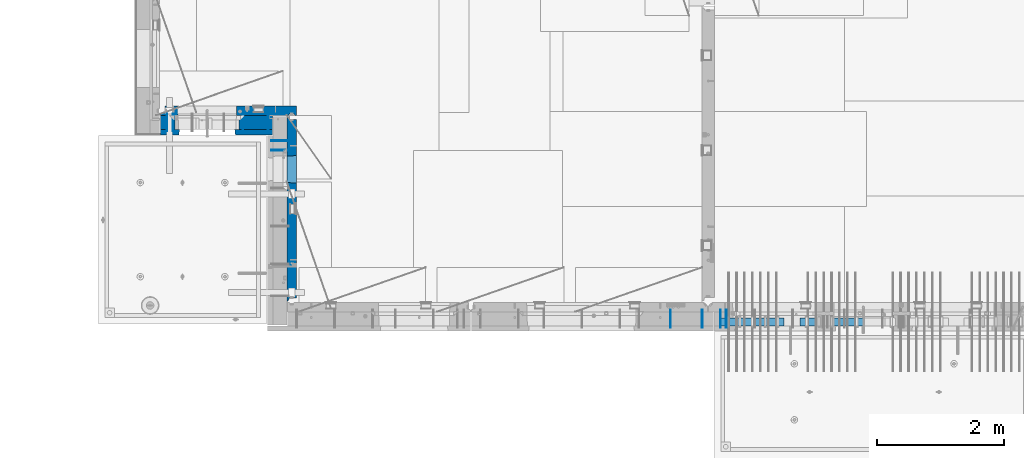
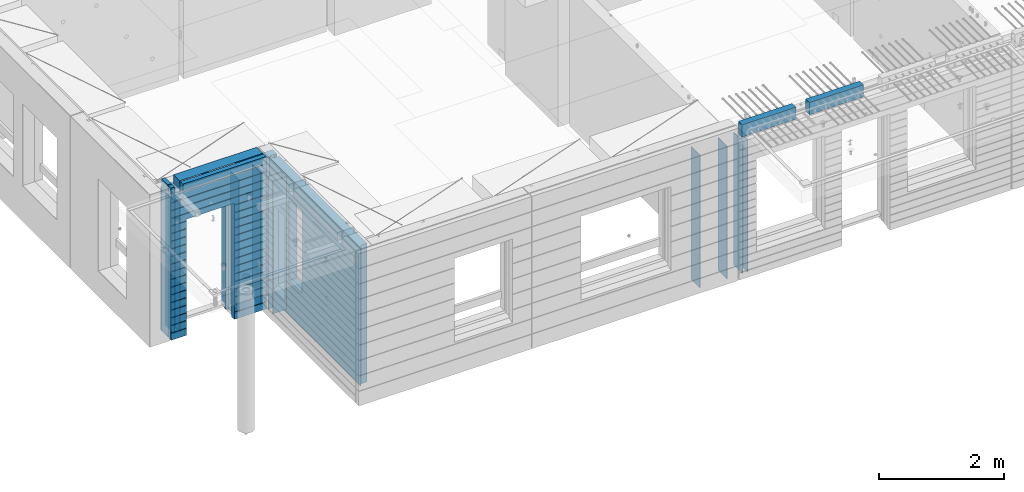
# One storey, part 218 of 334: 16 walls, 7 elements without a shape of their own.
"""IFC2X3 building model written with IfcOpenShell, lengths in millimetres."""

from ifc_helpers import new_model, si_unit, frame, origin_with_axes, place, context, subcontext, project, spatial, faceted_brep, material, type_object, element, aggregate, save


model = new_model("IFC2X3")

# Units and contexts
model_context = context("Model", 3, precision=1e-05, world=origin_with_axes())
body_context = subcontext(model_context, "Body", "Model", "MODEL_VIEW")
ifc_project = project(units=[si_unit("LENGTHUNIT", "METRE", prefix="MILLI"), si_unit("AREAUNIT", "SQUARE_METRE"), si_unit("VOLUMEUNIT", "CUBIC_METRE"), si_unit("MASSUNIT", "GRAM", prefix="KILO"), si_unit("TIMEUNIT", "SECOND"), si_unit("PLANEANGLEUNIT", "RADIAN"), si_unit("SOLIDANGLEUNIT", "STERADIAN"), si_unit("THERMODYNAMICTEMPERATUREUNIT", "DEGREE_CELSIUS"), si_unit("LUMINOUSINTENSITYUNIT", "LUMEN")], contexts=[model_context])

# Site, building, storey
site_placement = place(None, origin_with_axes())
site = spatial("IfcSite", under=ifc_project, at=site_placement, CompositionType="ELEMENT")
building_placement = place(site_placement, origin_with_axes())
building = spatial("IfcBuilding", under=site, at=building_placement, CompositionType="ELEMENT")
storey_placement = place(building_placement, origin_with_axes())
storey = spatial("IfcBuildingStorey", under=building, at=storey_placement, Name="3", CompositionType="ELEMENT", Elevation=0.0)

# Assembly, wall
assembly_1_placement = place(storey_placement, origin_with_axes())
assembly_1 = element("IfcElementAssembly", 1, at=assembly_1_placement, inside=storey, AssemblyPlace="NOTDEFINED", PredefinedType="REINFORCEMENT_UNIT")
ifc_material_1 = material(Name="Undefined")
wall_type_1 = type_object("IfcWallType", PredefinedType="NOTDEFINED")
wall_1_placement = place(assembly_1_placement, frame((16855.0, 7880.0, 89115.0), z_axis=(0.0, 0.0, 1.0), x_axis=(0.0, -1.0, 0.0)))
wall_1 = element("IfcWall", 2, at=wall_1_placement, type_object=wall_type_1, material=ifc_material_1, Name="(PD)", context=body_context, shape_type="Brep", body=[
    faceted_brep([(0.0, 5.0, -1300.0), (0.0, 5.0, 1300.0), (280.0, 5.0, 1300.0), (280.0, 5.0, -1300.0), (0.0, -5.0, 1300.0), (280.0, -5.0, 1300.0), (0.0, -5.0, -1300.0), (280.0, -5.0, -1300.0)], [[[0, 1, 2, 3]], [[1, 4, 5, 2]], [[4, 6, 7, 5]], [[6, 0, 3, 7]], [[5, 7, 3, 2]], [[6, 4, 1, 0]]]),
])

# Assembly, walls
assembly_2_placement = place(storey_placement, origin_with_axes())
assembly_2 = element("IfcElementAssembly", 3, at=assembly_2_placement, inside=storey, AssemblyPlace="NOTDEFINED", PredefinedType="REINFORCEMENT_UNIT")
wall_2_placement = place(assembly_2_placement, frame((16565.0, 7880.0, 89115.0), z_axis=(0.0, 0.0, 1.0), x_axis=(0.0, -1.0, 0.0)))
wall_2 = element("IfcWall", 4, at=wall_2_placement, type_object=wall_type_1, material=ifc_material_1, Name="(PD)", context=body_context, shape_type="Brep", body=[
    faceted_brep([(0.0, 5.0, -1300.0), (0.0, 5.0, 1300.0), (280.0, 5.0, 1300.0), (280.0, 5.0, -1300.0), (0.0, -5.0, 1300.0), (280.0, -5.0, 1300.0), (0.0, -5.0, -1300.0), (280.0, -5.0, -1300.0)], [[[0, 1, 2, 3]], [[1, 4, 5, 2]], [[4, 6, 7, 5]], [[6, 0, 3, 7]], [[5, 7, 3, 2]], [[6, 4, 1, 0]]]),
])
wall_3_placement = place(assembly_2_placement, frame((16065.0, 7880.0, 89115.0), z_axis=(0.0, 0.0, 1.0), x_axis=(0.0, -1.0, 0.0)))
wall_3 = element("IfcWall", 5, at=wall_3_placement, type_object=wall_type_1, material=ifc_material_1, Name="(PD)", context=body_context, shape_type="Brep", body=[
    faceted_brep([(0.0, 5.0, -1300.0), (0.0, 5.0, 1300.0), (280.0, 5.0, 1300.0), (280.0, 5.0, -1300.0), (0.0, -5.0, 1300.0), (280.0, -5.0, 1300.0), (0.0, -5.0, -1300.0), (280.0, -5.0, -1300.0)], [[[0, 1, 2, 3]], [[1, 4, 5, 2]], [[4, 6, 7, 5]], [[6, 0, 3, 7]], [[5, 7, 3, 2]], [[6, 4, 1, 0]]]),
])
aggregate(assembly_2, [wall_2, wall_3])

# Assembly, wall
assembly_3_placement = place(storey_placement, origin_with_axes())
assembly_3 = element("IfcElementAssembly", 6, at=assembly_3_placement, inside=storey, AssemblyPlace="NOTDEFINED", PredefinedType="REINFORCEMENT_UNIT")
wall_4_placement = place(assembly_3_placement, frame((8215.0, 10980.0, 89115.0), z_axis=(0.0, 0.0, 1.0), x_axis=(0.0, -1.0, 0.0)))
wall_4 = element("IfcWall", 7, at=wall_4_placement, type_object=wall_type_1, material=ifc_material_1, Name="(PD)", context=body_context, shape_type="Brep", body=[
    faceted_brep([(0.0, 5.0, -1300.0), (0.0, 5.0, 1300.0), (280.0, 5.0, 1300.0), (280.0, 5.0, -1300.0), (0.0, -5.0, 1300.0), (280.0, -5.0, 1300.0), (0.0, -5.0, -1300.0), (280.0, -5.0, -1300.0)], [[[0, 1, 2, 3]], [[1, 4, 5, 2]], [[4, 6, 7, 5]], [[6, 0, 3, 7]], [[5, 7, 3, 2]], [[6, 4, 1, 0]]]),
])

# Wall
wall_5_placement = place(assembly_1_placement, frame((16945.0, 7880.0, 89115.0), z_axis=(0.0, 0.0, 1.0), x_axis=(0.0, -1.0, 0.0)))
wall_5 = element("IfcWall", 8, at=wall_5_placement, type_object=wall_type_1, material=ifc_material_1, Name="(PD)", context=body_context, shape_type="Brep", body=[
    faceted_brep([(0.0, 5.0, -1300.0), (0.0, 5.0, 1300.0), (280.0, 5.0, 1300.0), (280.0, 5.0, -1300.0), (0.0, -5.0, 1300.0), (280.0, -5.0, 1300.0), (0.0, -5.0, -1300.0), (280.0, -5.0, -1300.0)], [[[0, 1, 2, 3]], [[1, 4, 5, 2]], [[4, 6, 7, 5]], [[6, 0, 3, 7]], [[5, 7, 3, 2]], [[6, 4, 1, 0]]]),
])

aggregate(assembly_1, [wall_1, wall_5])

wall_6_placement = place(assembly_3_placement, frame((8115.0, 10980.0, 89115.0), z_axis=(0.0, 0.0, 1.0), x_axis=(0.0, -1.0, 0.0)))
wall_6 = element("IfcWall", 9, at=wall_6_placement, type_object=wall_type_1, material=ifc_material_1, Name="(PD)", context=body_context, shape_type="Brep", body=[
    faceted_brep([(0.0, 5.0, -1300.0), (0.0, 5.0, 1300.0), (280.0, 5.0, 1300.0), (280.0, 5.0, -1300.0), (0.0, -5.0, 1300.0), (280.0, -5.0, 1300.0), (0.0, -5.0, -1300.0), (280.0, -5.0, -1300.0)], [[[0, 1, 2, 3]], [[1, 4, 5, 2]], [[4, 6, 7, 5]], [[6, 0, 3, 7]], [[5, 7, 3, 2]], [[6, 4, 1, 0]]]),
])

wall_7_placement = place(assembly_3_placement, frame((9315.0, 10980.0, 89115.0), z_axis=(0.0, 0.0, 1.0), x_axis=(0.0, -1.0, 0.0)))
wall_7 = element("IfcWall", 10, at=wall_7_placement, type_object=wall_type_1, material=ifc_material_1, Name="(PD)", context=body_context, shape_type="Brep", body=[
    faceted_brep([(0.0, 5.0, -1300.0), (0.0, 5.0, 1300.0), (280.0, 5.0, 1300.0), (280.0, 5.0, -1300.0), (0.0, -5.0, 1300.0), (280.0, -5.0, 1300.0), (0.0, -5.0, -1300.0), (280.0, -5.0, -1300.0)], [[[0, 1, 2, 3]], [[1, 4, 5, 2]], [[4, 6, 7, 5]], [[6, 0, 3, 7]], [[5, 7, 3, 2]], [[6, 4, 1, 0]]]),
])

wall_8_placement = place(assembly_3_placement, frame((9715.0, 10980.0, 89115.0), z_axis=(0.0, 0.0, 1.0), x_axis=(0.0, -1.0, 0.0)))
wall_8 = element("IfcWall", 11, at=wall_8_placement, type_object=wall_type_1, material=ifc_material_1, Name="(PD)", context=body_context, shape_type="Brep", body=[
    faceted_brep([(0.0, 5.0, -1300.0), (0.0, 5.0, 1300.0), (280.0, 5.0, 1300.0), (280.0, 5.0, -1300.0), (0.0, -5.0, 1300.0), (280.0, -5.0, 1300.0), (0.0, -5.0, -1300.0), (280.0, -5.0, -1300.0)], [[[0, 1, 2, 3]], [[1, 4, 5, 2]], [[4, 6, 7, 5]], [[6, 0, 3, 7]], [[5, 7, 3, 2]], [[6, 4, 1, 0]]]),
])

# Assembly, walls
assembly_4_placement = place(storey_placement, origin_with_axes())
assembly_4 = element("IfcElementAssembly", 12, at=assembly_4_placement, inside=storey, AssemblyPlace="NOTDEFINED", PredefinedType="REINFORCEMENT_UNIT")
wall_9_placement = place(assembly_4_placement, frame((10040.0, 10400.0, 89115.0), z_axis=(0.0, 0.0, 1.0), x_axis=(-1.0, 3.00000001838171e-08, 0.0)))
wall_9 = element("IfcWall", 13, at=wall_9_placement, type_object=wall_type_1, material=ifc_material_1, Name="(PD)", context=body_context, shape_type="Brep", body=[
    faceted_brep([(0.0, 5.0, -1300.0), (0.0, 5.0, 1300.0), (280.0, 5.0, 1300.0), (280.0, 5.0, -1300.0), (0.0, -5.0, 1300.0), (280.0, -5.0, 1300.0), (0.0, -5.0, -1300.0), (280.0, -5.0, -1300.0)], [[[0, 1, 2, 3]], [[1, 4, 5, 2]], [[4, 6, 7, 5]], [[6, 0, 3, 7]], [[5, 7, 3, 2]], [[6, 4, 1, 0]]]),
])
wall_10_placement = place(assembly_4_placement, frame((10040.0, 10550.0, 89115.0), z_axis=(0.0, 0.0, 1.0), x_axis=(-1.0, 3.00000001838171e-08, 0.0)))
wall_10 = element("IfcWall", 14, at=wall_10_placement, type_object=wall_type_1, material=ifc_material_1, Name="(PD)", context=body_context, shape_type="Brep", body=[
    faceted_brep([(0.0, 5.0, -1300.0), (0.0, 5.0, 1300.0), (280.0, 5.0, 1300.0), (280.0, 5.0, -1300.0), (0.0, -5.0, 1300.0), (280.0, -5.0, 1300.0), (0.0, -5.0, -1300.0), (280.0, -5.0, -1300.0)], [[[0, 1, 2, 3]], [[1, 4, 5, 2]], [[4, 6, 7, 5]], [[6, 0, 3, 7]], [[5, 7, 3, 2]], [[6, 4, 1, 0]]]),
])

# Assemblies, walls
assembly_5_placement = place(storey_placement, origin_with_axes())
assembly_5 = element("IfcElementAssembly", 15, at=assembly_5_placement, inside=storey, AssemblyPlace="NOTDEFINED", PredefinedType="REINFORCEMENT_UNIT")
assembly_6_placement = place(assembly_5_placement, origin_with_axes())
assembly_6 = element("IfcElementAssembly", 16, at=assembly_6_placement, Name="Steel Assembly", AssemblyPlace="NOTDEFINED", PredefinedType="NOTDEFINED")
ifc_material_2 = material()
wall_type_2 = type_object("IfcWallType", PredefinedType="NOTDEFINED")
wall_11_placement = place(assembly_6_placement, frame((16859.9998568133, 7690.00021946163, 90590.0), z_axis=(0.0, 0.0, 1.0), x_axis=(1.0, 0.0, 0.0)))
wall_11 = element("IfcWall", 17, at=wall_11_placement, type_object=wall_type_2, material=ifc_material_2, context=body_context, shape_type="Brep", body=[
    faceted_brep([(0.0, 60.0, -120.0), (0.0, 60.0, 120.0), (1000.0, 60.0, 120.0), (1000.0, 60.0, -120.0), (0.0, -60.0, 120.0), (1000.0, -60.0, 120.0), (0.0, -60.0, -120.0), (1000.0, -60.0, -120.0)], [[[0, 1, 2, 3]], [[1, 4, 5, 2]], [[4, 6, 7, 5]], [[6, 0, 3, 7]], [[5, 7, 3, 2]], [[6, 4, 1, 0]]]),
])
aggregate(assembly_6, [wall_11])
assembly_7_placement = place(assembly_5_placement, origin_with_axes())
assembly_7 = element("IfcElementAssembly", 18, at=assembly_7_placement, Name="Steel Assembly", AssemblyPlace="NOTDEFINED", PredefinedType="NOTDEFINED")
aggregate(assembly_5, [assembly_7, assembly_6])
wall_12_placement = place(assembly_7_placement, frame((18109.9998568133, 7690.00021946163, 90590.0), z_axis=(0.0, 0.0, 1.0), x_axis=(1.0, 0.0, 0.0)))
wall_12 = element("IfcWall", 19, at=wall_12_placement, type_object=wall_type_2, material=ifc_material_2, context=body_context, shape_type="Brep", body=[
    faceted_brep([(0.0, 60.0, -120.0), (0.0, 60.0, 120.0), (1000.0, 60.0, 120.0), (1000.0, 60.0, -120.0), (0.0, -60.0, 120.0), (1000.0, -60.0, 120.0), (0.0, -60.0, -120.0), (1000.0, -60.0, -120.0)], [[[0, 1, 2, 3]], [[1, 4, 5, 2]], [[4, 6, 7, 5]], [[6, 0, 3, 7]], [[5, 7, 3, 2]], [[6, 4, 1, 0]]]),
])
aggregate(assembly_7, [wall_12])

# Wall
ifc_material_3 = material(Name="COS5gt")
wall_type_3 = type_object("IfcWallType", PredefinedType="NOTDEFINED")
wall_13_placement = place(assembly_3_placement, frame((9784.0, 10840.0, 89247.5), z_axis=(0.0, 0.0, 1.0), x_axis=(-1.0, 3.00000001838171e-08, 0.0)))
wall_13 = element("IfcWall", 20, at=wall_13_placement, type_object=wall_type_3, material=ifc_material_3, context=body_context, shape_type="Brep", body=[
    faceted_brep([(1699.0, -110.0, 1492.5), (1699.0, 90.0, 1492.5), (1699.0, 90.0, 1442.5), (1699.0, 110.0, 1442.5), (1699.0, 110.0, 1222.5), (1699.0, -110.0, 1222.5), (1549.0, 110.0, 1222.5), (1549.0, -110.0, 1222.5), (1549.0, -110.0, 1492.5), (1549.0, 110.0, 1442.5), (1549.0, 90.0, 1442.5), (1549.0, 90.0, 1492.5), (0.0, -110.0, -1492.5), (0.0, 90.0, -1492.5), (529.001442432404, 90.0, -1492.5), (529.001442432404, -110.0, -1492.5), (0.0, 90.0, -1442.5), (0.0, 110.0, -1442.5), (529.001442432404, 110.0, -1442.5), (529.001442432404, 90.0, -1442.5), (1769.0, 90.0, -1442.5), (1769.0, 90.0, -1492.5), (1539.0014424324, 90.0, -1492.5), (1539.0014424324, 90.0, -1442.5), (1769.0, 110.0, -1442.5), (1539.0014424324, 110.0, -1442.5), (1769.0, 110.0, 1442.5), (1769.0, 90.0, 1442.5), (1769.0, 90.0, 1492.5), (1769.0, -110.0, 1492.5), (1769.0, -110.0, -1492.5), (1539.0014424324, -110.0, -1492.5), (1539.0014424324, -110.0, 847.5), (1539.0014424324, 110.0, 847.5), (529.001442432404, -110.0, 847.5), (529.001442432404, 110.0, 847.5), (0.0, -110.0, 1492.5), (0.0, 90.0, 1492.5), (0.0, 90.0, 1442.5), (0.0, 110.0, 1442.5)], [[[0, 1, 2, 3, 4, 5]], [[5, 4, 6, 7]], [[8, 7, 6, 9, 10, 11]], [[12, 13, 14, 15]], [[16, 17, 18, 19]], [[20, 21, 22, 23]], [[24, 20, 23, 25]], [[26, 27, 28, 29, 30, 21, 20, 24]], [[21, 30, 31, 22]], [[32, 33, 25, 23, 22, 31]], [[34, 35, 33, 32]], [[15, 14, 19, 18, 35, 34]], [[13, 16, 19, 14]], [[13, 12, 36, 37, 38, 39, 17, 16]], [[37, 36, 8, 11]], [[38, 37, 11, 10]], [[39, 38, 10, 9]], [[4, 3, 26, 24, 25, 33, 35, 18, 17, 39, 9, 6]], [[27, 26, 3, 2]], [[28, 27, 2, 1]], [[29, 28, 1, 0]], [[36, 12, 15, 34, 32, 31, 30, 29, 0, 5, 7, 8]]]),
])

ifc_material_4 = material(Name="CONCRETE/C30/37")
wall_type_4 = type_object("IfcWallType", PredefinedType="NOTDEFINED")
wall_14_placement = place(assembly_3_placement, frame((9784.0, 10687.5, 89247.5), z_axis=(0.0, 0.0, 1.0), x_axis=(-1.0, 3.00000001838171e-08, 0.0)))
wall_14 = element("IfcWall", 21, at=wall_14_placement, type_object=wall_type_4, material=ifc_material_4, context=body_context, shape_type="Brep", body=[
    faceted_brep([(1699.0, -42.5, 1492.5), (1699.0, 42.5, 1492.5), (1699.0, 42.5, 1356.99999988925), (1699.0, 32.4999991126988, 1355.00000040044), (1699.0, 32.4999992506928, 1344.99999999921), (1699.0, 42.5, 1342.99999994476), (1699.0, 42.5, 1222.5), (1699.0, -42.5, 1222.5), (1549.0, 42.5, 1222.5), (1549.0, -42.5, 1222.5), (1549.0, -42.5, 1492.5), (1549.0, 42.5, 1342.99999994476), (1549.0, 32.4999992506928, 1344.99999999921), (1549.0, 32.4999991126988, 1355.00000040044), (1549.0, 42.5, 1356.99999988925), (1549.0, 42.5, 1492.5), (1478.99938360887, 42.5, 606.999999889245), (1769.0, 42.5, 606.999999889245), (1769.0, 32.4999991126988, 605.00000040044), (1477.8227168378, 32.4999991126988, 605.00000040044), (1769.0, 32.4999992506928, 594.999999999214), (1477.82271685404, 32.4999992506928, 594.999999999214), (1769.0, 42.5, 592.999999944761), (1478.99938360887, 42.5, 592.999999944761), (1769.0, 42.5, 456.999999889245), (1478.99938360887, 42.5, 456.999999889245), (1769.0, 32.4999991126988, 455.00000040044), (1477.8227168378, 32.4999991126988, 455.00000040044), (1769.0, 32.4999992506928, 444.999999999214), (1477.82271685404, 32.4999992506928, 444.999999999214), (1769.0, 42.5, 442.999999944761), (1478.99938360887, 42.5, 442.999999944761), (1769.0, 42.5, 306.999999889245), (1478.99938360887, 42.5, 306.999999889245), (1769.0, 32.4999991126988, 305.00000040044), (1477.8227168378, 32.4999991126988, 305.00000040044), (1769.0, 32.4999992506928, 294.999999999214), (1477.82271685404, 32.4999992506928, 294.999999999214), (1769.0, 42.5, 292.999999944761), (1478.99938360887, 42.5, 292.999999944761), (1769.0, 42.5, 156.999999889245), (1478.99938360887, 42.5, 156.999999889245), (1769.0, 32.4999991126988, 155.00000040044), (1477.8227168378, 32.4999991126988, 155.00000040044), (1769.0, 32.4999992506928, 144.999999999214), (1477.82271685404, 32.4999992506928, 144.999999999214), (1769.0, 42.5, 142.999999944761), (1478.99938360887, 42.5, 142.999999944761), (1769.0, 42.5, 6.99999988924537), (1478.99938360887, 42.5, 6.99999988924537), (1769.0, 32.4999991126988, 5.0000004004396), (1477.8227168378, 32.4999991126988, 5.0000004004396), (1769.0, 32.4999992506928, -5.0000000007858), (1477.82271685404, 32.4999992506928, -5.0000000007858), (1769.0, 42.5, -7.00000005523907), (1478.99938360887, 42.5, -7.00000005523907), (1769.0, 42.5, -143.000000110755), (1478.99938360887, 42.5, -143.000000110755), (1769.0, 32.4999991126988, -144.99999959956), (1477.8227168378, 32.4999991126988, -144.99999959956), (1769.0, 32.4999992506928, -155.000000000786), (1477.82271685404, 32.4999992506928, -155.000000000786), (1769.0, 42.5, -157.000000055239), (1478.99938360887, 42.5, -157.000000055239), (1769.0, 42.5, -293.000000110755), (1478.99938360887, 42.5, -293.000000110755), (1769.0, 32.4999991126988, -294.99999959956), (1477.8227168378, 32.4999991126988, -294.99999959956), (1769.0, 32.4999992506928, -305.000000000786), (1477.82271685404, 32.4999992506928, -305.000000000786), (1769.0, 42.5, -307.000000055239), (1478.99938360887, 42.5, -307.000000055239), (1769.0, 42.5, -443.000000110755), (1478.99938360887, 42.5, -443.000000110755), (1769.0, 32.4999991126988, -444.99999959956), (1477.8227168378, 32.4999991126988, -444.99999959956), (1769.0, 32.4999992506928, -455.000000000786), (1477.82271685404, 32.4999992506928, -455.000000000786), (1769.0, 42.5, -457.000000055239), (1478.99938360887, 42.5, -457.000000055239), (1769.0, 42.5, -593.000000110755), (1478.99938360887, 42.5, -593.000000110755), (1769.0, 32.4999991126988, -594.99999959956), (1477.8227168378, 32.4999991126988, -594.99999959956), (1769.0, 32.4999992506928, -605.000000000786), (1477.82271685404, 32.4999992506928, -605.000000000786), (1769.0, 42.5, -607.000000055239), (1478.99938360887, 42.5, -607.000000055239), (1769.0, 42.5, -743.000000110755), (1478.99938360887, 42.5, -743.000000110755), (1769.0, 32.4999991126988, -744.99999959956), (1477.8227168378, 32.4999991126988, -744.99999959956), (1769.0, 32.4999992506928, -755.000000000786), (1477.82271685404, 32.4999992506928, -755.000000000786), (1769.0, 42.5, -757.000000055239), (1478.99938360887, 42.5, -757.000000055239), (1769.0, 42.5, -893.000000110755), (1478.99938360887, 42.5, -893.000000110755), (1769.0, 32.4999991126988, -894.99999959956), (1477.8227168378, 32.4999991126988, -894.99999959956), (1769.0, 32.4999992506928, -905.000000000786), (1477.82271685404, 32.4999992506928, -905.000000000786), (1769.0, 42.5, -907.000000055239), (1478.99938360887, 42.5, -907.000000055239), (1769.0, 42.5, -1043.00000011075), (1478.99938360887, 42.5, -1043.00000011075), (1769.0, 32.4999991126988, -1044.99999959956), (1477.8227168378, 32.4999991126988, -1044.99999959956), (1769.0, 32.4999992506928, -1055.00000000079), (1477.82271685404, 32.4999992506928, -1055.00000000079), (1769.0, 42.5, -1057.00000005524), (1478.99938360887, 42.5, -1057.00000005524), (1769.0, 42.5, -1193.00000011075), (1478.99938360887, 42.5, -1193.00000011075), (1769.0, 32.4999991126988, -1194.99999959956), (1477.8227168378, 32.4999991126988, -1194.99999959956), (1769.0, 32.4999992506928, -1205.00000000079), (1477.82271685404, 32.4999992506928, -1205.00000000079), (1769.0, 42.5, -1207.00000005524), (1478.99938360887, 42.5, -1207.00000005524), (1769.0, 42.5, -1343.00000011075), (1478.99938360887, 42.5, -1343.00000011075), (1769.0, 32.4999991126988, -1344.99999959956), (1477.8227168378, 32.4999991126988, -1344.99999959956), (1769.0, 32.4999992506928, -1355.00000000079), (1477.82271685404, 32.4999992506928, -1355.00000000079), (1769.0, 42.5, -1357.00000005524), (1478.99938360887, 42.5, -1357.00000005524), (1769.0, 42.5, -1492.5), (1478.99938360887, 42.5, -1492.5), (1769.0, -42.5, -1492.5), (1468.99771694221, -42.5, -1492.5), (599.001442432404, 42.5, 782.5), (1469.0014424324, 42.5, 782.5), (1478.99938360887, 42.5, 782.5), (1468.99771694221, -42.5, 787.502857142856), (599.001050275541, -42.5, 787.502857142856), (588.999383608874, 42.5, 782.5), (1478.99938360887, 42.5, 742.999999944761), (1468.99771694221, -42.5, 782.5), (1478.99938360887, 42.5, 756.999999889245), (1477.82271683781, 32.4999991126988, 755.00000040044), (1477.82271685404, 32.4999992506928, 744.999999999214), (1769.0, 42.5, 742.999999944761), (1769.0, 32.4999992506928, 744.999999999214), (1769.0, 32.4999991126988, 755.00000040044), (1769.0, 42.5, 756.999999889245), (0.0, 32.4999991127006, 905.00000040044), (1769.0, 32.4999991126988, 905.00000040044), (1769.0, 32.4999992506928, 894.999999999214), (0.0, 32.4999992507037, 894.999999999258), (0.0, 42.5, 906.999999889245), (1769.0, 42.5, 906.999999889245), (0.0, 42.5, 1042.99999994476), (1769.0, 42.5, 1042.99999994476), (0.0, 32.4999992507037, 1044.99999999926), (1769.0, 32.4999992506928, 1044.99999999921), (0.0, 32.4999991127006, 1055.00000040044), (1769.0, 32.4999991126988, 1055.00000040044), (0.0, 42.5, 1056.99999988925), (1769.0, 42.5, 1056.99999988925), (0.0, 42.5, 1192.99999994476), (1769.0, 42.5, 1192.99999994476), (0.0, 32.4999992507037, 1194.99999999926), (1769.0, 32.4999992506928, 1194.99999999921), (0.0, 32.4999991127006, 1205.00000040044), (1769.0, 32.4999991126988, 1205.00000040044), (0.0, 42.5, 1206.99999988925), (1769.0, 42.5, 1206.99999988925), (1769.0, 42.5, 1492.5), (1769.0, -42.5, 1492.5), (1769.0, 42.5, 892.999999944761), (1769.0, 42.5, 1342.99999994476), (1769.0, 32.4999992506928, 1344.99999999921), (1769.0, 32.4999991126988, 1355.00000040044), (1769.0, 42.5, 1356.99999988925), (0.0, 42.5, 892.999999944761), (588.999383608874, 42.5, 756.999999889245), (0.0, 42.5, 756.999999889245), (588.999383608874, 42.5, -1492.5), (0.0, 42.5, -1492.5), (0.0, 42.5, -1357.00000005524), (588.999383608874, 42.5, -1357.00000005524), (0.0, 32.4999992507037, -1355.00000000074), (590.176050363707, 32.4999992506928, -1355.00000000079), (0.0, 32.4999991127006, -1344.99999959956), (590.176050379945, 32.4999991126988, -1344.99999959956), (0.0, 42.5, -1343.00000011075), (588.999383608874, 42.5, -1343.00000011075), (0.0, 42.5, -1207.00000005524), (588.999383608874, 42.5, -1207.00000005524), (0.0, 32.4999992507037, -1205.00000000074), (590.176050363709, 32.4999992506928, -1205.00000000079), (0.0, 32.4999991127006, -1194.99999959956), (590.176050379947, 32.4999991126988, -1194.99999959956), (0.0, 42.5, -1193.00000011075), (588.999383608874, 42.5, -1193.00000011075), (0.0, 42.5, -1057.00000005524), (588.999383608874, 42.5, -1057.00000005524), (0.0, 32.4999992507037, -1055.00000000074), (590.176050363711, 32.4999992506928, -1055.00000000079), (0.0, 32.4999991127006, -1044.99999959956), (590.176050379947, 32.4999991126988, -1044.99999959956), (0.0, 42.5, -1043.00000011075), (588.999383608874, 42.5, -1043.00000011075), (0.0, 42.5, -907.000000055239), (588.999383608874, 42.5, -907.000000055239), (0.0, 32.4999992507037, -905.000000000742), (590.176050363711, 32.4999992506928, -905.000000000786), (0.0, 32.4999991127006, -894.99999959956), (590.176050379947, 32.4999991126988, -894.99999959956), (0.0, 42.5, -893.000000110755), (588.999383608874, 42.5, -893.000000110755), (0.0, 42.5, -757.000000055239), (588.999383608874, 42.5, -757.000000055239), (0.0, 32.4999992507037, -755.000000000742), (590.176050363711, 32.4999992506928, -755.000000000786), (0.0, 32.4999991127006, -744.99999959956), (590.176050379947, 32.4999991126988, -744.99999959956), (0.0, 42.5, -743.000000110755), (588.999383608874, 42.5, -743.000000110755), (0.0, 42.5, -607.000000055239), (588.999383608874, 42.5, -607.000000055239), (3.63797880709171e-12, 32.4999992507037, -605.000000000742), (590.176050363709, 32.4999992506928, -605.000000000786), (3.63797880709171e-12, 32.4999991127006, -594.99999959956), (590.176050379947, 32.4999991126988, -594.99999959956), (0.0, 42.5, -593.000000110755), (588.999383608874, 42.5, -593.000000110755), (0.0, 42.5, -457.000000055239), (588.999383608874, 42.5, -457.000000055239), (0.0, 32.4999992507037, -455.000000000742), (590.176050363711, 32.4999992506928, -455.000000000786), (0.0, 32.4999991127006, -444.99999959956), (590.176050379947, 32.4999991126988, -444.99999959956), (0.0, 42.5, -443.000000110755), (588.999383608874, 42.5, -443.000000110755), (0.0, 42.5, -307.000000055239), (588.999383608874, 42.5, -307.000000055239), (0.0, 32.4999992507037, -305.000000000742), (590.176050363711, 32.4999992506928, -305.000000000786), (0.0, 32.4999991127006, -294.99999959956), (590.176050379947, 32.4999991126988, -294.99999959956), (0.0, 42.5, -293.000000110755), (588.999383608874, 42.5, -293.000000110755), (0.0, 42.5, -157.000000055239), (588.999383608874, 42.5, -157.000000055239), (3.63797880709171e-12, 32.4999992507037, -155.000000000742), (590.176050363707, 32.4999992506928, -155.000000000786), (3.63797880709171e-12, 32.4999991127006, -144.99999959956), (590.176050379945, 32.4999991126988, -144.99999959956), (0.0, 42.5, -143.000000110755), (588.999383608874, 42.5, -143.000000110755), (0.0, 42.5, -7.00000005523907), (588.999383608874, 42.5, -7.00000005523907), (0.0, 32.4999992507037, -5.00000000074215), (590.176050363705, 32.4999992506928, -5.0000000007858), (0.0, 32.4999991127006, 5.0000004004396), (590.176050379941, 32.4999991126988, 5.0000004004396), (0.0, 42.5, 6.99999988924537), (588.999383608874, 42.5, 6.99999988924537), (0.0, 42.5, 142.999999944761), (588.999383608874, 42.5, 142.999999944761), (-3.63797880709171e-12, 32.4999992507037, 144.999999999258), (590.176050363705, 32.4999992506928, 144.999999999214), (-3.63797880709171e-12, 32.4999991127006, 155.00000040044), (590.176050379943, 32.4999991126988, 155.00000040044), (0.0, 42.5, 156.999999889245), (588.999383608874, 42.5, 156.999999889245), (0.0, 42.5, 292.999999944761), (588.999383608874, 42.5, 292.999999944761), (-3.63797880709171e-12, 32.4999992507037, 294.999999999258), (590.176050363703, 32.4999992506928, 294.999999999214), (-3.63797880709171e-12, 32.4999991127006, 305.00000040044), (590.17605037994, 32.4999991126988, 305.00000040044), (0.0, 42.5, 306.999999889245), (588.999383608874, 42.5, 306.999999889245), (0.0, 42.5, 442.999999944761), (588.999383608874, 42.5, 442.999999944761), (0.0, 32.4999992507037, 444.999999999258), (590.176050363702, 32.4999992506928, 444.999999999214), (0.0, 32.4999991127006, 455.00000040044), (590.176050379938, 32.4999991126988, 455.00000040044), (0.0, 42.5, 456.999999889245), (588.999383608874, 42.5, 456.999999889245), (0.0, 42.5, 592.999999944761), (588.999383608874, 42.5, 592.999999944761), (3.63797880709171e-12, 32.4999992507037, 594.999999999258), (590.176050363702, 32.4999992506928, 594.999999999214), (3.63797880709171e-12, 32.4999991127006, 605.00000040044), (590.17605037994, 32.4999991126988, 605.00000040044), (0.0, 42.5, 606.999999889245), (588.999383608874, 42.5, 606.999999889245), (0.0, 42.5, 742.999999944761), (588.999383608874, 42.5, 742.999999944761), (0.0, 32.4999992507037, 744.999999999258), (590.176050363705, 32.4999992506928, 744.999999999214), (0.0, 32.4999991127006, 755.00000040044), (590.176050379943, 32.4999991126988, 755.00000040044), (599.001050275541, -42.5, 782.5), (599.001050275539, -42.5, -1492.5), (0.0, -42.5, -1492.5), (-3.63797880709171e-12, 32.4999992507037, 1344.99999999926), (0.0, 42.5, 1342.99999994476), (0.0, -42.5, 1492.5), (0.0, 42.5, 1492.5), (0.0, 42.5, 1356.99999988925), (-3.63797880709171e-12, 32.4999991127006, 1355.00000040044)], [[[0, 1, 2, 3, 4, 5, 6, 7]], [[7, 6, 8, 9]], [[10, 9, 8, 11, 12, 13, 14, 15]], [[16, 17, 18, 19]], [[19, 18, 20, 21]], [[21, 20, 22, 23]], [[24, 25, 23, 22]], [[25, 24, 26, 27]], [[27, 26, 28, 29]], [[29, 28, 30, 31]], [[32, 33, 31, 30]], [[33, 32, 34, 35]], [[35, 34, 36, 37]], [[37, 36, 38, 39]], [[40, 41, 39, 38]], [[41, 40, 42, 43]], [[43, 42, 44, 45]], [[45, 44, 46, 47]], [[48, 49, 47, 46]], [[49, 48, 50, 51]], [[51, 50, 52, 53]], [[53, 52, 54, 55]], [[56, 57, 55, 54]], [[57, 56, 58, 59]], [[59, 58, 60, 61]], [[61, 60, 62, 63]], [[64, 65, 63, 62]], [[65, 64, 66, 67]], [[67, 66, 68, 69]], [[69, 68, 70, 71]], [[72, 73, 71, 70]], [[73, 72, 74, 75]], [[75, 74, 76, 77]], [[77, 76, 78, 79]], [[80, 81, 79, 78]], [[81, 80, 82, 83]], [[83, 82, 84, 85]], [[85, 84, 86, 87]], [[88, 89, 87, 86]], [[89, 88, 90, 91]], [[91, 90, 92, 93]], [[93, 92, 94, 95]], [[96, 97, 95, 94]], [[97, 96, 98, 99]], [[99, 98, 100, 101]], [[101, 100, 102, 103]], [[104, 105, 103, 102]], [[105, 104, 106, 107]], [[107, 106, 108, 109]], [[109, 108, 110, 111]], [[112, 113, 111, 110]], [[113, 112, 114, 115]], [[115, 114, 116, 117]], [[117, 116, 118, 119]], [[120, 121, 119, 118]], [[121, 120, 122, 123]], [[123, 122, 124, 125]], [[125, 124, 126, 127]], [[128, 129, 127, 126]], [[128, 130, 131, 129]], [[132, 133, 134, 135, 136, 137]], [[138, 16, 19, 21, 23, 25, 27, 29, 31, 33, 35, 37, 39, 41, 43, 45, 47, 49, 51, 53, 55, 57, 59, 61, 63, 65, 67, 69, 71, 73, 75, 77, 79, 81, 83, 85, 87, 89, 91, 93, 95, 97, 99, 101, 103, 105, 107, 109, 111, 113, 115, 117, 119, 121, 123, 125, 127, 129, 131, 139, 135, 134, 140, 141, 142]], [[17, 16, 138, 143]], [[142, 144, 143, 138]], [[141, 145, 144, 142]], [[140, 146, 145, 141]], [[147, 148, 149, 150]], [[151, 152, 148, 147]], [[152, 151, 153, 154]], [[155, 156, 154, 153]], [[157, 158, 156, 155]], [[159, 160, 158, 157]], [[160, 159, 161, 162]], [[163, 164, 162, 161]], [[165, 166, 164, 163]], [[167, 168, 166, 165]], [[169, 170, 130, 128, 126, 124, 122, 120, 118, 116, 114, 112, 110, 108, 106, 104, 102, 100, 98, 96, 94, 92, 90, 88, 86, 84, 82, 80, 78, 76, 74, 72, 70, 68, 66, 64, 62, 60, 58, 56, 54, 52, 50, 48, 46, 44, 42, 40, 38, 36, 34, 32, 30, 28, 26, 24, 22, 20, 18, 17, 143, 144, 145, 146, 171, 149, 148, 152, 154, 156, 158, 160, 162, 164, 166, 168, 172, 173, 174, 175]], [[150, 149, 171, 176]], [[146, 140, 134, 133, 132, 137, 177, 178, 176, 171]], [[179, 180, 181, 182]], [[183, 184, 182, 181]], [[185, 186, 184, 183]], [[187, 188, 186, 185]], [[188, 187, 189, 190]], [[191, 192, 190, 189]], [[193, 194, 192, 191]], [[195, 196, 194, 193]], [[196, 195, 197, 198]], [[199, 200, 198, 197]], [[201, 202, 200, 199]], [[203, 204, 202, 201]], [[204, 203, 205, 206]], [[207, 208, 206, 205]], [[209, 210, 208, 207]], [[211, 212, 210, 209]], [[212, 211, 213, 214]], [[215, 216, 214, 213]], [[217, 218, 216, 215]], [[219, 220, 218, 217]], [[220, 219, 221, 222]], [[223, 224, 222, 221]], [[225, 226, 224, 223]], [[227, 228, 226, 225]], [[228, 227, 229, 230]], [[231, 232, 230, 229]], [[233, 234, 232, 231]], [[235, 236, 234, 233]], [[236, 235, 237, 238]], [[239, 240, 238, 237]], [[241, 242, 240, 239]], [[243, 244, 242, 241]], [[244, 243, 245, 246]], [[247, 248, 246, 245]], [[249, 250, 248, 247]], [[251, 252, 250, 249]], [[252, 251, 253, 254]], [[255, 256, 254, 253]], [[257, 258, 256, 255]], [[259, 260, 258, 257]], [[260, 259, 261, 262]], [[263, 264, 262, 261]], [[265, 266, 264, 263]], [[267, 268, 266, 265]], [[268, 267, 269, 270]], [[271, 272, 270, 269]], [[273, 274, 272, 271]], [[275, 276, 274, 273]], [[276, 275, 277, 278]], [[279, 280, 278, 277]], [[281, 282, 280, 279]], [[283, 284, 282, 281]], [[284, 283, 285, 286]], [[287, 288, 286, 285]], [[289, 290, 288, 287]], [[291, 292, 290, 289]], [[292, 291, 293, 294]], [[295, 296, 294, 293]], [[297, 298, 296, 295]], [[178, 177, 298, 297]], [[137, 136, 299, 300, 179, 182, 184, 186, 188, 190, 192, 194, 196, 198, 200, 202, 204, 206, 208, 210, 212, 214, 216, 218, 220, 222, 224, 226, 228, 230, 232, 234, 236, 238, 240, 242, 244, 246, 248, 250, 252, 254, 256, 258, 260, 262, 264, 266, 268, 270, 272, 274, 276, 278, 280, 282, 284, 286, 288, 290, 292, 294, 296, 298, 177]], [[301, 180, 179, 300]], [[302, 303, 167, 165, 163, 161, 159, 157, 155, 153, 151, 147, 150, 176, 178, 297, 295, 293, 291, 289, 287, 285, 283, 281, 279, 277, 275, 273, 271, 269, 267, 265, 263, 261, 259, 257, 255, 253, 251, 249, 247, 245, 243, 241, 239, 237, 235, 233, 231, 229, 227, 225, 223, 221, 219, 217, 215, 213, 211, 209, 207, 205, 203, 201, 199, 197, 195, 193, 191, 189, 187, 185, 183, 181, 180, 301, 304, 305, 306, 307]], [[305, 304, 10, 15]], [[306, 305, 15, 14]], [[307, 306, 14, 13]], [[302, 307, 13, 12]], [[303, 302, 12, 11]], [[6, 5, 172, 168, 167, 303, 11, 8]], [[173, 172, 5, 4]], [[174, 173, 4, 3]], [[175, 174, 3, 2]], [[169, 175, 2, 1]], [[170, 169, 1, 0]], [[304, 301, 300, 299, 136, 135, 139, 131, 130, 170, 0, 7, 9, 10]]]),
])

ifc_material_5 = material(Name="CONCRETE/C25/30")
wall_type_5 = type_object("IfcWallType", PredefinedType="NOTDEFINED")
wall_15_placement = place(assembly_3_placement, frame((10160.0, 11025.0, 89112.5), z_axis=(0.0, 0.0, 1.0), x_axis=(-1.0, 3.00000001838171e-08, 0.0)))
wall_15 = element("IfcWall", 22, at=wall_15_placement, type_object=wall_type_5, material=ifc_material_5, context=body_context, shape_type="Brep", body=[
    faceted_brep([(47.9999996848892, 54.9999994175323, 1357.5), (47.9999996848892, 54.9999994175323, -1357.5), (34.999999998452, 55.0000022791301, -1357.5), (34.999999998452, 55.0000022791301, 1357.5), (24.999999998452, 75.0000022791301, 1357.5), (24.999999998452, 75.0, -1357.5), (124.999999998452, 75.0, 1357.5), (124.999999998452, 75.0, -1357.5), (114.999999998452, 55.0000022791301, -1357.5), (114.999999998452, 55.0000022791301, 1357.5), (101.99999958942, 54.999999390373, 1357.5), (101.99999958942, 54.999999390373, -1357.5), (945.001442432404, -75.0, -1357.5), (949.055496486459, 75.0, -1357.5), (949.055496486457, 75.0, 948.445945945947), (945.001442432404, -75.0, 952.5), (0.0, -75.0, -1357.5), (0.0, 75.0, -1357.5), (2145.0, 75.0, 1357.5), (2145.0, 75.0, -1357.5), (1870.94738837835, 75.0, -1357.5), (1870.94738837835, 75.0, 948.445945945947), (2145.0, 45.0, 1357.5), (2145.0, 45.0, -1357.5), (2074.9999995581, 32.0, 1357.5), (2074.9999995581, 32.0, -1357.5), (2074.9999995581, -75.0, 1357.5), (2074.9999995581, -75.0, -1357.5), (1875.0014424324, -75.0, -1357.5), (1875.0014424324, -75.0, 952.5), (0.0, -75.0, 1357.5), (0.0, 75.0, 1357.5)], [[[0, 1, 2, 3]], [[4, 3, 2, 5]], [[6, 7, 8, 9]], [[10, 9, 8, 11]], [[10, 11, 1, 0]], [[12, 13, 14, 15]], [[1, 11, 8, 7, 13, 12, 16, 17, 5, 2]], [[18, 19, 20, 21, 14, 13, 7, 6]], [[19, 18, 22, 23]], [[24, 25, 23, 22]], [[26, 27, 25, 24]], [[19, 23, 25, 27, 28, 20]], [[20, 28, 29, 21]], [[15, 14, 21, 29]], [[28, 27, 26, 30, 16, 12, 15, 29]], [[16, 30, 31, 17]], [[17, 31, 4, 5]], [[31, 30, 26, 24, 22, 18, 6, 9, 10, 0, 3, 4]]]),
])

aggregate(assembly_3, [wall_4, wall_6, wall_7, wall_8, wall_14, wall_13, wall_15])

wall_16_placement = place(assembly_4_placement, frame((10085.0, 8000.0, 89112.5), z_axis=(0.0, 0.0, 1.0), x_axis=(0.0, 1.0, 0.0)))
wall_16 = element("IfcWall", 23, at=wall_16_placement, type_object=wall_type_5, material=ifc_material_5, context=body_context, shape_type="Brep", body=[
    faceted_brep([(2934.99999772087, 40.0, 1357.5), (2934.99999772087, 75.0, 1357.5), (15.0, 75.0, 1357.5), (15.0, 65.0, 1357.5), (65.0, 35.0, 1357.5), (65.0, -75.0, 1357.5), (2885.0, -75.0, 1357.5), (2885.0, 27.0, 1357.5), (15.0, 75.0, -1357.5), (15.0, 65.0, -1357.5), (65.0, 35.0, -1357.5), (65.0, -75.0, -1357.5), (2885.0, -75.0, -1357.5), (1885.00042424099, -75.0000000030959, -682.5), (1885.00042424099, -75.0000000030959, 952.5), (2315.00042424099, -75.0000000030959, 952.5), (2315.00042424099, -75.0000000030959, -682.5), (2885.0, 27.0, -1357.5), (2934.99999772087, 75.0, -1357.5), (2934.99999772087, 40.0, -1357.5), (1889.05447829513, 75.0, -678.445945945859), (2310.94637018685, 75.0, -678.445945945859), (2310.94637018685, 75.0, 948.445945945859), (1889.05447829513, 75.0, 948.445945945859)], [[[0, 1, 2, 3, 4, 5, 6, 7]], [[2, 8, 9, 3]], [[3, 9, 10, 4]], [[5, 4, 10, 11]], [[5, 11, 12, 6], [13, 14, 15, 16]], [[6, 12, 17, 7]], [[11, 10, 9, 8, 18, 19, 17, 12]], [[7, 17, 19, 0]], [[18, 1, 0, 19]], [[8, 2, 1, 18], [20, 21, 22, 23]], [[15, 22, 21, 16]], [[14, 23, 22, 15]], [[13, 20, 23, 14]], [[16, 21, 20, 13]]]),
])

aggregate(assembly_4, [wall_9, wall_10, wall_16])

save(model, "model.ifc")
